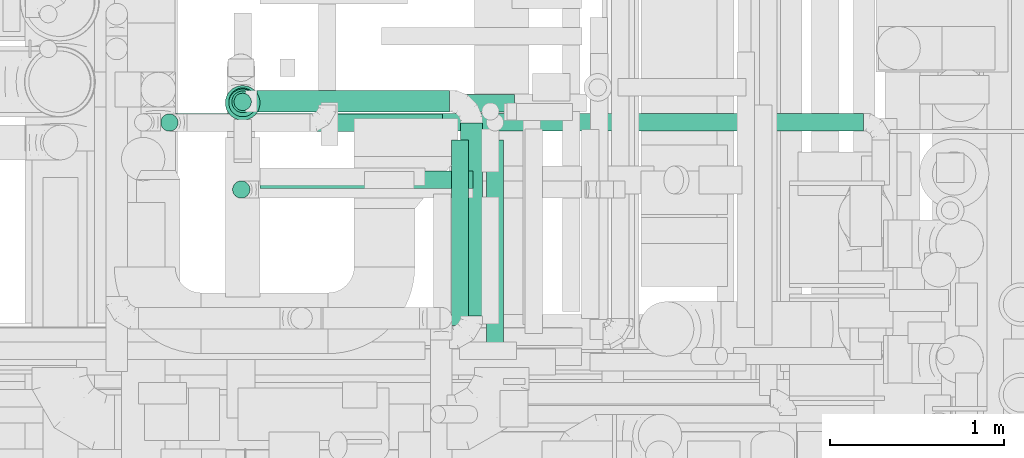
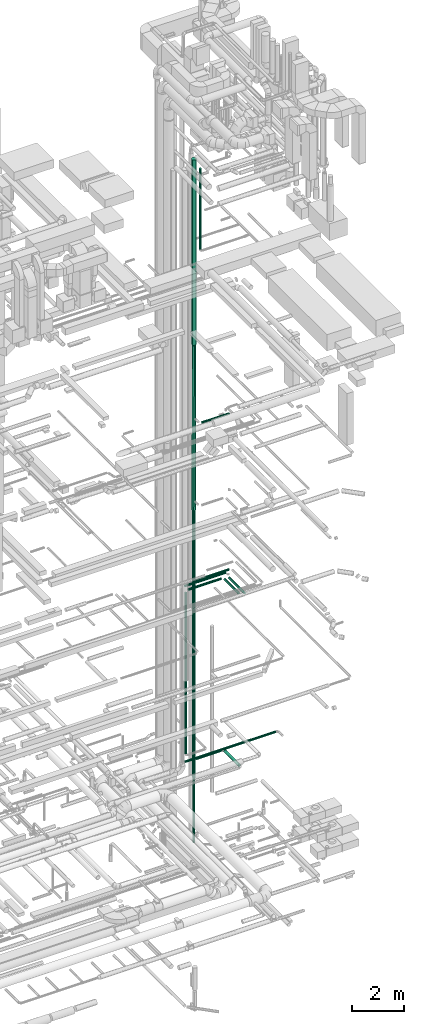
# One storey, part 66 of 337: 15 flow segments.
"""IFC2X3 building model written with IfcOpenShell, lengths in millimetres."""

from ifc_helpers import new_model, entity, si_unit, converted_unit, derived_unit, direction, frame, origin, origin_2d_with_axis, place, context, subcontext, project, spatial, circle, extrude, type_object, element, save


model = new_model("IFC2X3")

# Units and contexts
model_context = context("Model", 3, precision=0.01, world=origin(), true_north=direction((6.12303176911189e-17, 1.0)))
body_context = subcontext(model_context, "Body", "Model", "MODEL_VIEW")
ifc_project = project(units=[si_unit("LENGTHUNIT", "METRE", prefix="MILLI"), si_unit("AREAUNIT", "SQUARE_METRE"), si_unit("VOLUMEUNIT", "CUBIC_METRE"), converted_unit("PLANEANGLEUNIT", "DEGREE", entity("IfcRatioMeasure", 0.0174532925199433), si_unit("PLANEANGLEUNIT", "RADIAN"), dimensions=[0, 0, 0, 0, 0, 0, 0]), si_unit("MASSUNIT", "GRAM", prefix="KILO"), derived_unit("MASSDENSITYUNIT", [(si_unit("MASSUNIT", "GRAM", prefix="KILO"), 1), (si_unit("LENGTHUNIT", "METRE"), -3)]), derived_unit("MOMENTOFINERTIAUNIT", [(si_unit("LENGTHUNIT", "METRE"), 4)]), si_unit("TIMEUNIT", "SECOND"), si_unit("FREQUENCYUNIT", "HERTZ"), si_unit("THERMODYNAMICTEMPERATUREUNIT", "DEGREE_CELSIUS"), derived_unit("THERMALTRANSMITTANCEUNIT", [(si_unit("MASSUNIT", "GRAM", prefix="KILO"), 1), (si_unit("THERMODYNAMICTEMPERATUREUNIT", "KELVIN"), -1), (si_unit("TIMEUNIT", "SECOND"), -3)]), derived_unit("VOLUMETRICFLOWRATEUNIT", [(si_unit("LENGTHUNIT", "METRE"), 3), (si_unit("TIMEUNIT", "SECOND"), -1)]), derived_unit("MASSFLOWRATEUNIT", [(si_unit("MASSUNIT", "GRAM", prefix="KILO"), 1), (si_unit("TIMEUNIT", "SECOND"), -1)]), derived_unit("ROTATIONALFREQUENCYUNIT", [(si_unit("TIMEUNIT", "SECOND"), -1)]), si_unit("ELECTRICCURRENTUNIT", "AMPERE"), si_unit("ELECTRICVOLTAGEUNIT", "VOLT"), si_unit("POWERUNIT", "WATT"), si_unit("FORCEUNIT", "NEWTON", prefix="KILO"), si_unit("ILLUMINANCEUNIT", "LUX"), si_unit("LUMINOUSFLUXUNIT", "LUMEN"), si_unit("LUMINOUSINTENSITYUNIT", "CANDELA"), derived_unit("USERDEFINED", [(si_unit("MASSUNIT", "GRAM", prefix="KILO"), -1), (si_unit("LENGTHUNIT", "METRE"), -2), (si_unit("TIMEUNIT", "SECOND"), 3), (si_unit("LUMINOUSFLUXUNIT", "LUMEN"), 1)]), derived_unit("LINEARVELOCITYUNIT", [(si_unit("LENGTHUNIT", "METRE"), 1), (si_unit("TIMEUNIT", "SECOND"), -1)]), si_unit("PRESSUREUNIT", "PASCAL"), derived_unit("USERDEFINED", [(si_unit("LENGTHUNIT", "METRE"), -2), (si_unit("MASSUNIT", "GRAM", prefix="KILO"), 1), (si_unit("TIMEUNIT", "SECOND"), -2)]), derived_unit("LINEARFORCEUNIT", [(si_unit("MASSUNIT", "GRAM", prefix="KILO"), 1), (si_unit("LENGTHUNIT", "METRE"), 1), (si_unit("TIMEUNIT", "SECOND"), -2), (si_unit("LENGTHUNIT", "METRE"), -1)]), derived_unit("PLANARFORCEUNIT", [(si_unit("MASSUNIT", "GRAM", prefix="KILO"), 1), (si_unit("LENGTHUNIT", "METRE"), 1), (si_unit("TIMEUNIT", "SECOND"), -2), (si_unit("LENGTHUNIT", "METRE"), -2)])], contexts=[model_context])

# Site, building, storey
site_placement = place(None, origin())
site = spatial("IfcSite", under=ifc_project, at=site_placement, CompositionType="ELEMENT")
building_placement = place(site_placement, origin())
building = spatial("IfcBuilding", under=site, at=building_placement, CompositionType="ELEMENT")
storey_placement = place(building_placement, origin())
storey = spatial("IfcBuildingStorey", under=building, at=storey_placement, CompositionType="ELEMENT", Elevation=0.0)

# Flow segments
duct_segment_type = type_object("IfcDuctSegmentType", PredefinedType="NOTDEFINED")
flow_segment_1_placement = place(storey_placement, frame((68562.03, 11622.18, -800.0)))
element("IfcFlowSegment", 1, at=flow_segment_1_placement, inside=storey, type_object=duct_segment_type, context=body_context, shape_type="SweptSolid", body=[
    extrude(circle(Radius=50.0, at=origin_2d_with_axis()), frame((51.6, 51.6, 0.0), z_axis=(0.0, 0.0, 1.0), x_axis=(0.0, 1.0, 0.0)), (0.0, 0.0, 1.0), 3020.00000000001),
])
flow_segment_2_placement = place(storey_placement, frame((68695.68, 11614.73, 11448.4)))
element("IfcFlowSegment", 2, at=flow_segment_2_placement, inside=storey, type_object=duct_segment_type, context=body_context, shape_type="SweptSolid", body=[
    extrude(circle(Radius=50.0, at=origin_2d_with_axis()), frame((0.0, 51.6, 51.6), z_axis=(1.0, 0.0, 0.0), x_axis=(0.0, 1.0, 0.0)), (0.0, 0.0, 1.0), 1483.22813680747),
])
flow_segment_3_placement = place(storey_placement, frame((68291.62, 11502.7, 11228.4)))
element("IfcFlowSegment", 3, at=flow_segment_3_placement, inside=storey, type_object=duct_segment_type, context=body_context, shape_type="SweptSolid", body=[
    extrude(circle(Radius=50.0, at=origin_2d_with_axis()), frame((0.0, 51.6, 51.6), z_axis=(1.0, 0.0, 0.0), x_axis=(0.0, 1.0, 0.0)), (0.0, 0.0, 1.0), 1474.16018754507),
])
flow_segment_4_placement = place(storey_placement, frame((68696.01, 11613.48, 3035.9)))
element("IfcFlowSegment", 4, at=flow_segment_4_placement, inside=storey, type_object=duct_segment_type, context=body_context, shape_type="SweptSolid", body=[
    extrude(circle(Radius=62.5, at=origin_2d_with_axis()), frame((0.01, 64.1, 64.1), z_axis=(0.999999996128215, 8.79975570472207e-05, 0.0), x_axis=(-8.79975570472207e-05, 0.999999996128215, 0.0)), (0.0, 0.0, 1.0), 1110.1871095145),
])
flow_segment_5_placement = place(storey_placement, frame((69867.12, 10440.5, 3035.9)))
element("IfcFlowSegment", 5, at=flow_segment_5_placement, inside=storey, type_object=duct_segment_type, context=body_context, shape_type="SweptSolid", body=[
    extrude(circle(Radius=62.5, at=origin_2d_with_axis()), frame((64.1, 0.0, 64.1), z_axis=(0.0, 1.0, 0.0), x_axis=(-1.0, 0.0, 0.0)), (0.0, 0.0, 1.0), 1112.17649982139),
])
flow_segment_6_placement = place(storey_placement, frame((68549.53, 11609.7, 2245.0)))
element("IfcFlowSegment", 6, at=flow_segment_6_placement, inside=storey, type_object=duct_segment_type, context=body_context, shape_type="SweptSolid", body=[
    extrude(circle(Radius=62.5, at=origin_2d_with_axis()), frame((64.1, 64.1, 0.0), z_axis=(0.0, 0.0, 1.0), x_axis=(0.0, 1.0, 0.0)), (0.0, 0.0, 1.0), 12580.1988503505),
])
flow_segment_7_placement = place(storey_placement, frame((68140.83, 11503.66, 11448.4)))
element("IfcFlowSegment", 7, at=flow_segment_7_placement, inside=storey, type_object=duct_segment_type, context=body_context, shape_type="SweptSolid", body=[
    extrude(circle(Radius=50.0, at=origin_2d_with_axis()), frame((0.0, 51.6, 51.6), z_axis=(1.0, 0.0, 0.0), x_axis=(0.0, 1.0, 0.0)), (0.0, 0.0, 1.0), 1826.45361800965),
])
flow_segment_8_placement = place(storey_placement, frame((70015.69, 10255.6, 11228.4)))
element("IfcFlowSegment", 8, at=flow_segment_8_placement, inside=storey, type_object=duct_segment_type, context=body_context, shape_type="SweptSolid", body=[
    extrude(circle(Radius=50.0, at=origin_2d_with_axis()), frame((51.6, 0.0, 51.6), z_axis=(0.0, 1.0, 0.0), x_axis=(-1.0, 0.0, 0.0)), (0.0, 0.0, 1.0), 1199.65080337108),
])
flow_segment_9_placement = place(storey_placement, frame((68532.03, 11585.98, 14860.14)))
element("IfcFlowSegment", 9, at=flow_segment_9_placement, inside=storey, type_object=duct_segment_type, context=body_context, shape_type="SweptSolid", body=[
    extrude(circle(Radius=80.0, at=origin_2d_with_axis()), frame((81.6, 87.79, 0.06), z_axis=(0.0, -0.00079647972137066, 0.999999682809976), x_axis=(0.0, 0.999999682809976, 0.00079647972137066)), (0.0, 0.0, 1.0), 7774.99752274589),
])
flow_segment_10_placement = place(storey_placement, frame((68512.03, 11565.98, 22675.19)))
element("IfcFlowSegment", 10, at=flow_segment_10_placement, inside=storey, type_object=duct_segment_type, context=body_context, shape_type="SweptSolid", body=[
    extrude(circle(Radius=100.0, at=origin_2d_with_axis()), frame((101.6, 101.6, 0.0), z_axis=(0.0, 0.0, 1.0), x_axis=(-1.0, 0.0, 0.0)), (0.0, 0.0, 1.0), 8724.80610415691),
])
flow_segment_11_placement = place(storey_placement, frame((68713.6, 11173.6, 19148.4)))
element("IfcFlowSegment", 11, at=flow_segment_11_placement, inside=storey, type_object=duct_segment_type, context=body_context, shape_type="SweptSolid", body=[
    extrude(circle(Radius=50.0, at=origin_2d_with_axis()), frame((0.0, 51.6, 51.6), z_axis=(1.0, -5.76960361283527e-08, 0.0), x_axis=(-5.76960361283527e-08, -1.0, 0.0)), (0.0, 0.0, 1.0), 1226.22467377199),
])
flow_segment_12_placement = place(storey_placement, frame((68140.83, 11503.66, 3168.4)))
element("IfcFlowSegment", 12, at=flow_segment_12_placement, inside=storey, type_object=duct_segment_type, context=body_context, shape_type="SweptSolid", body=[
    extrude(circle(Radius=50.0, at=origin_2d_with_axis()), frame((0.0, 51.6, 51.6), z_axis=(1.0, 0.0, 0.0), x_axis=(0.0, -1.0, 0.0)), (0.0, 0.0, 1.0), 4048.36688259829),
])
flow_segment_13_placement = place(storey_placement, frame((68140.03, 11502.7, 3600.0)))
element("IfcFlowSegment", 13, at=flow_segment_13_placement, inside=storey, type_object=duct_segment_type, context=body_context, shape_type="SweptSolid", body=[
    extrude(circle(Radius=50.0, at=origin_2d_with_axis()), frame((51.6, 51.6, 0.0), z_axis=(0.0, 0.0, 1.0), x_axis=(0.0, 1.0, 0.0)), (0.0, 0.0, 1.0), 7580.00000000002),
])
flow_segment_14_placement = place(storey_placement, frame((69814.19, 10386.33, 11228.4)))
element("IfcFlowSegment", 14, at=flow_segment_14_placement, inside=storey, type_object=duct_segment_type, context=body_context, shape_type="SweptSolid", body=[
    extrude(circle(Radius=50.0, at=origin_2d_with_axis()), frame((51.6, 0.0, 51.6), z_axis=(0.0, 1.0, 0.0), x_axis=(1.0, 0.0, 0.0)), (0.0, 0.0, 1.0), 1067.96420540233),
])
flow_segment_15_placement = place(storey_placement, frame((68553.94, 11116.95, 27450.0)))
element("IfcFlowSegment", 15, at=flow_segment_15_placement, inside=storey, type_object=duct_segment_type, context=body_context, shape_type="SweptSolid", body=[
    extrude(circle(Radius=50.0, at=origin_2d_with_axis()), frame((51.6, 51.6, 0.0), z_axis=(0.0, 0.0, 1.0), x_axis=(0.0, -1.0, 0.0)), (0.0, 0.0, 1.0), 3800.00000000003),
])

save(model, "model.ifc")
